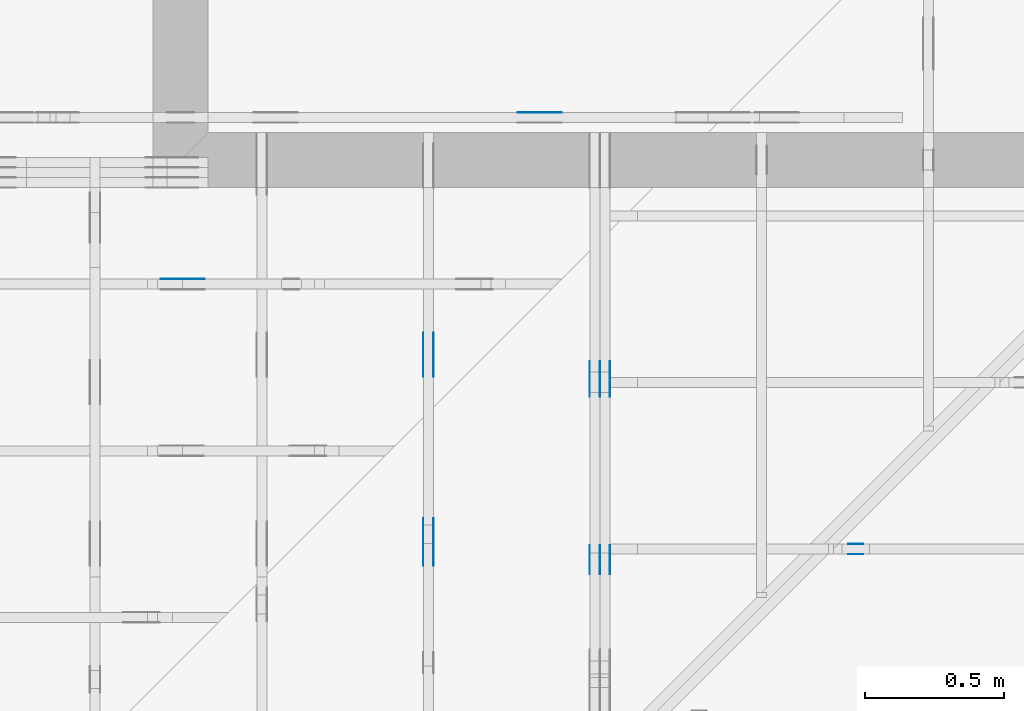
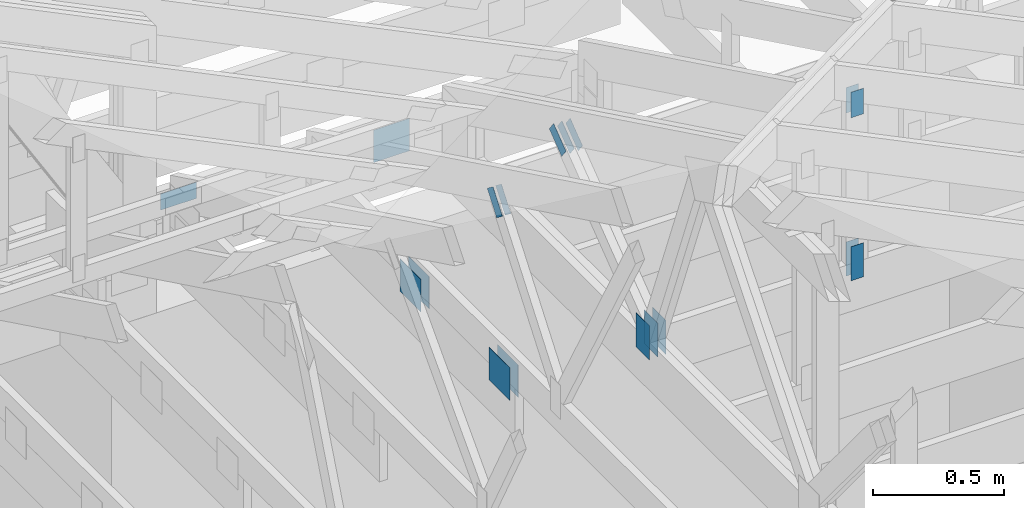
# One storey, part 130 of 159: 20 plates, 5 elements without a shape of their own.
"""IFC2X3 building model written with IfcOpenShell, lengths in millimetres."""

from ifc_helpers import new_model, si_unit, frame, origin, origin_with_axes, origin_2d, place, context, project, spatial, faceted_brep, element, aggregate, save


model = new_model("IFC2X3")

# Units and contexts
model_context = context("Model", 3, precision=1e-05, world=origin())
plan_context = context("Plan", 2, precision=1e-05, world=origin_2d())
ifc_project = project(units=[si_unit("LENGTHUNIT", "METRE", prefix="MILLI"), si_unit("AREAUNIT", "SQUARE_METRE"), si_unit("VOLUMEUNIT", "CUBIC_METRE"), si_unit("SOLIDANGLEUNIT", "STERADIAN"), si_unit("PLANEANGLEUNIT", "RADIAN"), si_unit("MASSUNIT", "GRAM"), si_unit("TIMEUNIT", "SECOND"), si_unit("THERMODYNAMICTEMPERATUREUNIT", "DEGREE_CELSIUS"), si_unit("LUMINOUSINTENSITYUNIT", "LUMEN")], contexts=[model_context, plan_context])

# Site, building, storey
site_placement = place(None, origin_with_axes())
site = spatial("IfcSite", under=ifc_project, at=site_placement, CompositionType="ELEMENT")
building_placement = place(site_placement, origin_with_axes())
building = spatial("IfcBuilding", under=site, at=building_placement, Name="Plan 1", CompositionType="ELEMENT")
storey_placement = place(building_placement, origin_with_axes())
storey = spatial("IfcBuildingStorey", under=building, at=storey_placement, Name="Etasje 1", CompositionType="ELEMENT", Elevation=0.0)

# Assembly, plate
assembly_1_placement = place(storey_placement, frame((10000.012663278096, 9072.000080051337, 1.1021457184401395e-15), z_axis=(9.811600543477555e-09, 1.0, 6.123031769111886e-17), x_axis=(-1.0, 9.811600543477555e-09, 0.0)))
assembly_1 = element("IfcElementAssembly", 1, at=assembly_1_placement, inside=storey, Name="T9 (79)", AssemblyPlace="FACTORY", PredefinedType="TRUSS")
plate_1_placement = place(assembly_1_placement, frame((-7973.47314453125, 147.0, 0.0), z_axis=(0.0, 0.0, 1.0), x_axis=(1.0, 0.0, 0.0)))
plate_1 = element("IfcPlate", 2, at=plate_1_placement, Name="GNT100S 152x159", context=model_context, shape_type="Brep", body=[
    faceted_brep([(159.0, 152.0, 1.0), (0.0, 152.0, 1.0), (0.0, 0.0, 1.0), (159.0, 0.0, 1.0), (0.0, 152.0, 0.0), (159.0, 152.0, 1.9471241025775798e-14), (159.0, 0.0, 1.9471241025775798e-14), (0.0, 0.0, 0.0), (159.00006797736023, -2.9206874025489785e-14, 1.7883461753452272e-30), (159.00006797736023, -2.9145643707798666e-14, 1.0), (6.797736023145262e-05, 6.121783086503054e-17, 1.0), (6.797736023145262e-05, -1.248682608832642e-20, 7.645723283419777e-37), (159.00006797736023, 152.0, 0.0), (159.00006797736023, 152.0, 1.0), (159.00006797736023, 0.0, 1.0), (159.00006797736023, 0.0, 0.0), (6.797736023145262e-05, 152.0, 0.0), (6.797736023145262e-05, 152.0, 1.0), (159.00006797736023, 152.0, 1.0), (159.00006797736023, 152.0, 0.0), (6.797736023145262e-05, 0.0, 0.0), (6.797736023151385e-05, -7.498303609110687e-33, 1.0), (6.797736025012787e-05, 152.0, 1.0), (6.797736025006664e-05, 152.0, -1.1397420192804459e-30)], [[[0, 1, 2, 3]], [[4, 5, 6, 7]], [[8, 9, 10, 11]], [[12, 13, 14, 15]], [[16, 17, 18, 19]], [[20, 21, 22, 23]]]),
])
aggregate(assembly_1, [plate_1])

# Assembly, plates
assembly_2_placement = place(storey_placement, frame((18074.541652722903, -699.9989301294845, 4.408582873760558e-15), z_axis=(-1.0, 1.836909530733566e-16, 6.123031769111886e-17), x_axis=(-1.836909530733566e-16, -1.0, 0.0)))
assembly_2 = element("IfcElementAssembly", 3, at=assembly_2_placement, inside=storey, Name="V5 (30)", AssemblyPlace="FACTORY", PredefinedType="TRUSS")
plate_2_placement = place(assembly_2_placement, frame((-8110.484134151697, 143.49999999999974, 0.0), z_axis=(0.0, 0.0, 1.0), x_axis=(6.123031769111886e-17, 1.0, 0.0)))
plate_2 = element("IfcPlate", 4, at=plate_2_placement, Name="GNT100S 103x159", context=model_context, shape_type="Brep", body=[
    faceted_brep([(159.00000000000023, 103.00024084830329, 1.0), (2.2737367544323206e-13, 103.00024084830329, 1.0), (2.5579538487363607e-13, 0.0002408483032922959, 1.0), (159.00000000000023, 0.0002408483032922959, 1.0), (2.2737367544323206e-13, 103.00024084830329, 2.78443247639729e-29), (159.00000000000023, 103.00024084830329, 1.9471241025775827e-14), (159.00000000000023, 0.0002408483032922959, 1.9471241025775827e-14), (2.5579538487363607e-13, 0.0002408483032922959, 3.1324865359469514e-29), (159.0, -2.92068615386637e-14, 1.788345410772899e-30), (159.0, -2.914563122097258e-14, 1.0), (2.842170943040401e-14, 6.123031769111364e-17, 1.0), (2.842170943040401e-14, -5.220810893244919e-30, 3.1967190959864043e-46), (159.0, 103.0, 0.0), (159.0, 103.0, 1.0), (159.0, 0.0, 1.0), (159.0, 0.0, 0.0), (0.0, 103.0, 0.0), (-3.7491518045553436e-33, 103.0, 1.0), (159.0, 102.99999999999999, 1.0), (159.0, 102.99999999999999, -7.888609052210118e-31), (2.8421709430404004e-14, 0.0, 3.503246160812043e-46), (2.8482939748095126e-14, -7.498303609110687e-33, 1.0), (4.109638519246561e-14, 103.0, 1.0), (4.1035154874774493e-14, 103.0, -2.5125955694867067e-30)], [[[0, 1, 2, 3]], [[4, 5, 6, 7]], [[8, 9, 10, 11]], [[12, 13, 14, 15]], [[16, 17, 18, 19]], [[20, 21, 22, 23]]]),
])
plate_3_placement = place(assembly_2_placement, frame((-8110.484134151697, 143.49999999999974, -37.0), z_axis=(0.0, 0.0, 1.0), x_axis=(6.123031769111886e-17, 1.0, 0.0)))
plate_3 = element("IfcPlate", 5, at=plate_3_placement, Name="GNT100S 103x159", context=model_context, shape_type="Brep", body=[
    faceted_brep([(159.00000000000023, 103.00024084830329, 1.0), (2.2737367544323206e-13, 103.00024084830329, 1.0), (2.5579538487363607e-13, 0.0002408483032922959, 1.0), (159.00000000000023, 0.0002408483032922959, 1.0), (2.2737367544323206e-13, 103.00024084830329, 2.78443247639729e-29), (159.00000000000023, 103.00024084830329, 1.9471241025775827e-14), (159.00000000000023, 0.0002408483032922959, 1.9471241025775827e-14), (2.5579538487363607e-13, 0.0002408483032922959, 3.1324865359469514e-29), (159.0, -2.92068615386637e-14, 1.788345410772899e-30), (159.0, -2.914563122097258e-14, 1.0), (2.842170943040401e-14, 6.123031769111364e-17, 1.0), (2.842170943040401e-14, -5.220810893244919e-30, 3.1967190959864043e-46), (159.0, 103.0, 0.0), (159.0, 103.0, 1.0), (159.0, 0.0, 1.0), (159.0, 0.0, 0.0), (0.0, 103.0, 0.0), (-3.7491518045553436e-33, 103.0, 1.0), (159.0, 102.99999999999999, 1.0), (159.0, 102.99999999999999, -7.888609052210118e-31), (2.8421709430404004e-14, 0.0, 3.503246160812043e-46), (2.8482939748095126e-14, -7.498303609110687e-33, 1.0), (4.109638519246561e-14, 103.0, 1.0), (4.1035154874774493e-14, 103.0, -2.5125955694867067e-30)], [[[0, 1, 2, 3]], [[4, 5, 6, 7]], [[8, 9, 10, 11]], [[12, 13, 14, 15]], [[16, 17, 18, 19]], [[20, 21, 22, 23]]]),
])
plate_4_placement = place(assembly_2_placement, frame((-8110.484134151697, 143.49999999999974, -36.0), z_axis=(0.0, 0.0, 1.0), x_axis=(6.123031769111886e-17, 1.0, 0.0)))
plate_4 = element("IfcPlate", 6, at=plate_4_placement, Name="GNT100S 103x159", context=model_context, shape_type="Brep", body=[
    faceted_brep([(159.00000000000023, 103.00024084830329, 1.0), (2.2737367544323206e-13, 103.00024084830329, 1.0), (2.5579538487363607e-13, 0.0002408483032922959, 1.0), (159.00000000000023, 0.0002408483032922959, 1.0), (2.2737367544323206e-13, 103.00024084830329, 2.78443247639729e-29), (159.00000000000023, 103.00024084830329, 1.9471241025775827e-14), (159.00000000000023, 0.0002408483032922959, 1.9471241025775827e-14), (2.5579538487363607e-13, 0.0002408483032922959, 3.1324865359469514e-29), (159.0, -2.92068615386637e-14, 1.788345410772899e-30), (159.0, -2.914563122097258e-14, 1.0), (2.842170943040401e-14, 6.123031769111364e-17, 1.0), (2.842170943040401e-14, -5.220810893244919e-30, 3.1967190959864043e-46), (159.0, 103.0, 0.0), (159.0, 103.0, 1.0), (159.0, 0.0, 1.0), (159.0, 0.0, 0.0), (0.0, 103.0, 0.0), (-3.7491518045553436e-33, 103.0, 1.0), (159.0, 102.99999999999999, 1.0), (159.0, 102.99999999999999, -7.888609052210118e-31), (2.8421709430404004e-14, 0.0, 3.503246160812043e-46), (2.8482939748095126e-14, -7.498303609110687e-33, 1.0), (4.109638519246561e-14, 103.0, 1.0), (4.1035154874774493e-14, 103.0, -2.5125955694867067e-30)], [[[0, 1, 2, 3]], [[4, 5, 6, 7]], [[8, 9, 10, 11]], [[12, 13, 14, 15]], [[16, 17, 18, 19]], [[20, 21, 22, 23]]]),
])
plate_5_placement = place(assembly_2_placement, frame((-8110.484134151697, 143.49999999999974, -73.0), z_axis=(0.0, 0.0, 1.0), x_axis=(6.123031769111886e-17, 1.0, 0.0)))
plate_5 = element("IfcPlate", 7, at=plate_5_placement, Name="GNT100S 103x159", context=model_context, shape_type="Brep", body=[
    faceted_brep([(159.00000000000023, 103.00024084830329, 1.0), (2.2737367544323206e-13, 103.00024084830329, 1.0), (2.5579538487363607e-13, 0.0002408483032922959, 1.0), (159.00000000000023, 0.0002408483032922959, 1.0), (2.2737367544323206e-13, 103.00024084830329, 2.78443247639729e-29), (159.00000000000023, 103.00024084830329, 1.9471241025775827e-14), (159.00000000000023, 0.0002408483032922959, 1.9471241025775827e-14), (2.5579538487363607e-13, 0.0002408483032922959, 3.1324865359469514e-29), (159.0, -2.92068615386637e-14, 1.788345410772899e-30), (159.0, -2.914563122097258e-14, 1.0), (2.842170943040401e-14, 6.123031769111364e-17, 1.0), (2.842170943040401e-14, -5.220810893244919e-30, 3.1967190959864043e-46), (159.0, 103.0, 0.0), (159.0, 103.0, 1.0), (159.0, 0.0, 1.0), (159.0, 0.0, 0.0), (0.0, 103.0, 0.0), (-3.7491518045553436e-33, 103.0, 1.0), (159.0, 102.99999999999999, 1.0), (159.0, 102.99999999999999, -7.888609052210118e-31), (2.8421709430404004e-14, 0.0, 3.503246160812043e-46), (2.8482939748095126e-14, -7.498303609110687e-33, 1.0), (4.109638519246561e-14, 103.0, 1.0), (4.1035154874774493e-14, 103.0, -2.5125955694867067e-30)], [[[0, 1, 2, 3]], [[4, 5, 6, 7]], [[8, 9, 10, 11]], [[12, 13, 14, 15]], [[16, 17, 18, 19]], [[20, 21, 22, 23]]]),
])
plate_6_placement = place(assembly_2_placement, frame((-8876.552454339913, 758.5722089171368, 0.0), z_axis=(0.0, 0.0, 1.0), x_axis=(0.7964129491034228, -0.6047531847790377, 0.0)))
plate_6 = element("IfcPlate", 8, at=plate_6_placement, Name="GNT100S 55x119", context=model_context, shape_type="Brep", body=[
    faceted_brep([(119.00024115164888, 55.00002240925187, 1.0), (0.0, 55.00002240925187, 1.0), (0.0005573403959715506, 0.0004177808596068644, 1.0), (119.0000207450239, 0.0004177808596068644, 1.0), (0.0, 55.00002240925187, 0.0), (119.00024115164888, 55.00002240925187, 1.4572845142070435e-14), (119.0000207450239, 0.0, 1.4572818150935097e-14), (0.0005573403959715506, 0.0, 6.825225901486405e-20), (119.00029540911692, 0.00021945880050767798, 1.3384505936089834e-30), (119.00029540911692, 0.0002194588005077392, 1.0), (0.0002954091169158346, 0.00021945880052959843, 1.0), (0.0002954091169158346, 0.0002194588005295372, 3.009265538105056e-36), (119.00029540911692, 55.00021945880144, -5.522026336547083e-29), (119.00029540911692, 55.00021945880144, 1.0), (119.00029540911692, 0.00021945880052953726, 1.0), (119.00029540911692, 0.00021945880052953726, 0.0), (0.0002954091169158346, 55.00021945880144, 0.0), (0.0002954091169158346, 55.00021945880144, 1.0), (119.00029540911783, 55.00021945880143, 1.0), (119.00029540911783, 55.00021945880143, -3.944304526105059e-31), (0.0002954091169158346, 0.00021945880052953726, -3.009265538105056e-36), (0.00029540911691589586, 0.00021945880052953726, 1.0), (0.0002954091169226312, 55.00021945880144, 1.0), (0.00029540911692256994, 55.00021945880144, -4.124078049351455e-31)], [[[0, 1, 2, 3]], [[4, 5, 6, 7]], [[8, 9, 10, 11]], [[12, 13, 14, 15]], [[16, 17, 18, 19]], [[20, 21, 22, 23]]]),
])
plate_7_placement = place(assembly_2_placement, frame((-8876.552454339913, 758.5722089171368, -37.0), z_axis=(0.0, 0.0, 1.0), x_axis=(0.7964129491034228, -0.6047531847790377, 0.0)))
plate_7 = element("IfcPlate", 9, at=plate_7_placement, Name="GNT100S 55x119", context=model_context, shape_type="Brep", body=[
    faceted_brep([(119.00024115164888, 55.00002240925187, 1.0), (0.0, 55.00002240925187, 1.0), (0.0005573403959715506, 0.0004177808596068644, 1.0), (119.0000207450239, 0.0004177808596068644, 1.0), (0.0, 55.00002240925187, 0.0), (119.00024115164888, 55.00002240925187, 1.4572845142070435e-14), (119.0000207450239, 0.0, 1.4572818150935097e-14), (0.0005573403959715506, 0.0, 6.825225901486405e-20), (119.00029540911692, 0.00021945880050767798, 1.3384505936089834e-30), (119.00029540911692, 0.0002194588005077392, 1.0), (0.0002954091169158346, 0.00021945880052959843, 1.0), (0.0002954091169158346, 0.0002194588005295372, 3.009265538105056e-36), (119.00029540911692, 55.00021945880144, -5.522026336547083e-29), (119.00029540911692, 55.00021945880144, 1.0), (119.00029540911692, 0.00021945880052953726, 1.0), (119.00029540911692, 0.00021945880052953726, 0.0), (0.0002954091169158346, 55.00021945880144, 0.0), (0.0002954091169158346, 55.00021945880144, 1.0), (119.00029540911783, 55.00021945880143, 1.0), (119.00029540911783, 55.00021945880143, -3.944304526105059e-31), (0.0002954091169158346, 0.00021945880052953726, -3.009265538105056e-36), (0.00029540911691589586, 0.00021945880052953726, 1.0), (0.0002954091169226312, 55.00021945880144, 1.0), (0.00029540911692256994, 55.00021945880144, -4.124078049351455e-31)], [[[0, 1, 2, 3]], [[4, 5, 6, 7]], [[8, 9, 10, 11]], [[12, 13, 14, 15]], [[16, 17, 18, 19]], [[20, 21, 22, 23]]]),
])
plate_8_placement = place(assembly_2_placement, frame((-8876.552454339913, 758.5722089171368, -36.0), z_axis=(0.0, 0.0, 1.0), x_axis=(0.7964129491034228, -0.6047531847790377, 0.0)))
plate_8 = element("IfcPlate", 10, at=plate_8_placement, Name="GNT100S 55x119", context=model_context, shape_type="Brep", body=[
    faceted_brep([(119.00024115164888, 55.00002240925187, 1.0), (0.0, 55.00002240925187, 1.0), (0.0005573403959715506, 0.0004177808596068644, 1.0), (119.0000207450239, 0.0004177808596068644, 1.0), (0.0, 55.00002240925187, 0.0), (119.00024115164888, 55.00002240925187, 1.4572845142070435e-14), (119.0000207450239, 0.0, 1.4572818150935097e-14), (0.0005573403959715506, 0.0, 6.825225901486405e-20), (119.00029540911692, 0.00021945880050767798, 1.3384505936089834e-30), (119.00029540911692, 0.0002194588005077392, 1.0), (0.0002954091169158346, 0.00021945880052959843, 1.0), (0.0002954091169158346, 0.0002194588005295372, 3.009265538105056e-36), (119.00029540911692, 55.00021945880144, -5.522026336547083e-29), (119.00029540911692, 55.00021945880144, 1.0), (119.00029540911692, 0.00021945880052953726, 1.0), (119.00029540911692, 0.00021945880052953726, 0.0), (0.0002954091169158346, 55.00021945880144, 0.0), (0.0002954091169158346, 55.00021945880144, 1.0), (119.00029540911783, 55.00021945880143, 1.0), (119.00029540911783, 55.00021945880143, -3.944304526105059e-31), (0.0002954091169158346, 0.00021945880052953726, -3.009265538105056e-36), (0.00029540911691589586, 0.00021945880052953726, 1.0), (0.0002954091169226312, 55.00021945880144, 1.0), (0.00029540911692256994, 55.00021945880144, -4.124078049351455e-31)], [[[0, 1, 2, 3]], [[4, 5, 6, 7]], [[8, 9, 10, 11]], [[12, 13, 14, 15]], [[16, 17, 18, 19]], [[20, 21, 22, 23]]]),
])
plate_9_placement = place(assembly_2_placement, frame((-8876.552454339913, 758.5722089171368, -73.0), z_axis=(0.0, 0.0, 1.0), x_axis=(0.7964129491034228, -0.6047531847790377, 0.0)))
plate_9 = element("IfcPlate", 11, at=plate_9_placement, Name="GNT100S 55x119", context=model_context, shape_type="Brep", body=[
    faceted_brep([(119.00024115164888, 55.00002240925187, 1.0), (0.0, 55.00002240925187, 1.0), (0.0005573403959715506, 0.0004177808596068644, 1.0), (119.0000207450239, 0.0004177808596068644, 1.0), (0.0, 55.00002240925187, 0.0), (119.00024115164888, 55.00002240925187, 1.4572845142070435e-14), (119.0000207450239, 0.0, 1.4572818150935097e-14), (0.0005573403959715506, 0.0, 6.825225901486405e-20), (119.00029540911692, 0.00021945880050767798, 1.3384505936089834e-30), (119.00029540911692, 0.0002194588005077392, 1.0), (0.0002954091169158346, 0.00021945880052959843, 1.0), (0.0002954091169158346, 0.0002194588005295372, 3.009265538105056e-36), (119.00029540911692, 55.00021945880144, -5.522026336547083e-29), (119.00029540911692, 55.00021945880144, 1.0), (119.00029540911692, 0.00021945880052953726, 1.0), (119.00029540911692, 0.00021945880052953726, 0.0), (0.0002954091169158346, 55.00021945880144, 0.0), (0.0002954091169158346, 55.00021945880144, 1.0), (119.00029540911783, 55.00021945880143, 1.0), (119.00029540911783, 55.00021945880143, -3.944304526105059e-31), (0.0002954091169158346, 0.00021945880052953726, -3.009265538105056e-36), (0.00029540911691589586, 0.00021945880052953726, 1.0), (0.0002954091169226312, 55.00021945880144, 1.0), (0.00029540911692256994, 55.00021945880144, -4.124078049351455e-31)], [[[0, 1, 2, 3]], [[4, 5, 6, 7]], [[8, 9, 10, 11]], [[12, 13, 14, 15]], [[16, 17, 18, 19]], [[20, 21, 22, 23]]]),
])
aggregate(assembly_2, [plate_2, plate_3, plate_4, plate_5, plate_6, plate_7, plate_8, plate_9])

assembly_3_placement = place(storey_placement, frame((17475.02226140475, -699.9989301294827, 1.1021457184401395e-15), z_axis=(-1.0, 1.836909530733566e-16, 6.123031769111886e-17), x_axis=(-1.836909530733566e-16, -1.0, 0.0)))
assembly_3 = element("IfcElementAssembly", 12, at=assembly_3_placement, inside=storey, Name="V6 (31)", AssemblyPlace="FACTORY", PredefinedType="TRUSS")
plate_10_placement = place(assembly_3_placement, frame((-8312.218750000002, 1032.4410400390623, 0.0), z_axis=(0.0, 0.0, 1.0), x_axis=(0.6077192601701954, -0.7941519381190169, 0.0)))
plate_10 = element("IfcPlate", 13, at=plate_10_placement, Name="GNT100S 55x119", context=model_context, shape_type="Brep", body=[
    faceted_brep([(119.00007993496365, 55.00028215261682, 1.0), (0.00021435704820760293, 55.00028215261682, 1.0), (0.0, 0.0, 1.0), (119.00045905375555, 0.0, 1.0), (0.00021435704820760293, 55.00028215261682, 2.6250300322164017e-20), (119.00007993496365, 55.00028215261682, 1.4572825399372727e-14), (119.00045905375555, 0.0005855320823684451, 1.457287182650087e-14), (0.0, 0.0005855320823684451, 0.0), (119.00022031500066, 0.00023279101330987532, 1.3384490889762144e-30), (119.00022031500066, 0.00023279101330993656, 1.0), (0.0002203150006607757, 0.00023279101333179578, 1.0), (0.0002203150006607757, 0.00023279101333173455, 3.009265538105056e-36), (119.00022031500066, 55.00023279101333, 5.522026336547083e-29), (119.00022031500066, 55.00023279101333, 1.0), (119.00022031500066, 0.00023279101333173458, 1.0), (119.00022031500066, 0.00023279101333173458, 0.0), (0.000220314999751281, 55.00023279101333, 0.0), (0.000220314999751281, 55.00023279101333, 1.0), (119.00022031499975, 55.000232791013325, 1.0), (119.00022031499975, 55.000232791013325, -3.944304526105059e-31), (0.00022031500066077575, 0.00023279101333173455, -4.513898307157584e-36), (0.00022031500066083698, 0.00023279101333173455, 1.0), (0.00022031499976385077, 55.00023279101333, 1.0), (0.00022031499976378954, 55.00023279101333, -7.659032184308083e-31)], [[[0, 1, 2, 3]], [[4, 5, 6, 7]], [[8, 9, 10, 11]], [[12, 13, 14, 15]], [[16, 17, 18, 19]], [[20, 21, 22, 23]]]),
])
plate_11_placement = place(assembly_3_placement, frame((-8312.218750000002, 1032.4410400390623, -37.00000000000001), z_axis=(0.0, 0.0, 1.0), x_axis=(0.6077192601701954, -0.7941519381190169, 0.0)))
plate_11 = element("IfcPlate", 14, at=plate_11_placement, Name="GNT100S 55x119", context=model_context, shape_type="Brep", body=[
    faceted_brep([(119.00007993496365, 55.00028215261682, 1.0), (0.00021435704820760293, 55.00028215261682, 1.0), (0.0, 0.0, 1.0), (119.00045905375555, 0.0, 1.0), (0.00021435704820760293, 55.00028215261682, 2.6250300322164017e-20), (119.00007993496365, 55.00028215261682, 1.4572825399372727e-14), (119.00045905375555, 0.0005855320823684451, 1.457287182650087e-14), (0.0, 0.0005855320823684451, 0.0), (119.00022031500066, 0.00023279101330987532, 1.3384490889762144e-30), (119.00022031500066, 0.00023279101330993656, 1.0), (0.0002203150006607757, 0.00023279101333179578, 1.0), (0.0002203150006607757, 0.00023279101333173455, 3.009265538105056e-36), (119.00022031500066, 55.00023279101333, 5.522026336547083e-29), (119.00022031500066, 55.00023279101333, 1.0), (119.00022031500066, 0.00023279101333173458, 1.0), (119.00022031500066, 0.00023279101333173458, 0.0), (0.000220314999751281, 55.00023279101333, 0.0), (0.000220314999751281, 55.00023279101333, 1.0), (119.00022031499975, 55.000232791013325, 1.0), (119.00022031499975, 55.000232791013325, -3.944304526105059e-31), (0.00022031500066077575, 0.00023279101333173455, -4.513898307157584e-36), (0.00022031500066083698, 0.00023279101333173455, 1.0), (0.00022031499976385077, 55.00023279101333, 1.0), (0.00022031499976378954, 55.00023279101333, -7.659032184308083e-31)], [[[0, 1, 2, 3]], [[4, 5, 6, 7]], [[8, 9, 10, 11]], [[12, 13, 14, 15]], [[16, 17, 18, 19]], [[20, 21, 22, 23]]]),
])
plate_12_placement = place(assembly_3_placement, frame((-8140.0, 299.0, 0.0), z_axis=(0.0, 0.0, 1.0), x_axis=(-1.0, 1.2246063538223773e-16, 0.0)))
plate_12 = element("IfcPlate", 15, at=plate_12_placement, Name="GNT100S 152x159", context=model_context, shape_type="Brep", body=[
    faceted_brep([(159.0, 151.99999999999997, 1.0), (0.0, 151.99999999999997, 1.0), (0.0, 0.0, 1.0), (159.0, 0.0, 1.0), (0.0, 151.99999999999997, 0.0), (159.0, 151.99999999999997, 1.9471241025775798e-14), (159.0, 0.0, 1.9471241025775798e-14), (0.0, 0.0, 0.0), (159.0, -2.92068615386637e-14, 1.788345410772899e-30), (159.0, -2.914563122097258e-14, 1.0), (1.1247455413666031e-32, 6.123031769111886e-17, 1.0), (0.0, 0.0, 0.0), (159.0, 152.0, 0.0), (159.0, 152.0, 1.0), (159.0, 0.0, 1.0), (159.0, 0.0, 0.0), (0.0, 151.99999999999997, 0.0), (0.0, 151.99999999999997, 1.0), (159.0, 152.0, 1.0), (159.0, 152.0, 0.0), (0.0, 0.0, 0.0), (6.123031769111886e-17, -7.498303609110687e-33, 1.0), (1.867524689579125e-14, 151.99999999999997, 1.0), (1.861401657810013e-14, 151.99999999999997, -1.1397421485848243e-30)], [[[0, 1, 2, 3]], [[4, 5, 6, 7]], [[8, 9, 10, 11]], [[12, 13, 14, 15]], [[16, 17, 18, 19]], [[20, 21, 22, 23]]]),
])
plate_13_placement = place(assembly_3_placement, frame((-8140.0, 299.0, -37.0), z_axis=(0.0, 0.0, 1.0), x_axis=(-1.0, 1.2246063538223773e-16, 0.0)))
plate_13 = element("IfcPlate", 16, at=plate_13_placement, Name="GNT100S 152x159", context=model_context, shape_type="Brep", body=[
    faceted_brep([(159.0, 151.99999999999997, 1.0), (0.0, 151.99999999999997, 1.0), (0.0, 0.0, 1.0), (159.0, 0.0, 1.0), (0.0, 151.99999999999997, 0.0), (159.0, 151.99999999999997, 1.9471241025775798e-14), (159.0, 0.0, 1.9471241025775798e-14), (0.0, 0.0, 0.0), (159.0, -2.92068615386637e-14, 1.788345410772899e-30), (159.0, -2.914563122097258e-14, 1.0), (1.1247455413666031e-32, 6.123031769111886e-17, 1.0), (0.0, 0.0, 0.0), (159.0, 152.0, 0.0), (159.0, 152.0, 1.0), (159.0, 0.0, 1.0), (159.0, 0.0, 0.0), (0.0, 151.99999999999997, 0.0), (0.0, 151.99999999999997, 1.0), (159.0, 152.0, 1.0), (159.0, 152.0, 0.0), (0.0, 0.0, 0.0), (6.123031769111886e-17, -7.498303609110687e-33, 1.0), (1.867524689579125e-14, 151.99999999999997, 1.0), (1.861401657810013e-14, 151.99999999999997, -1.1397421485848243e-30)], [[[0, 1, 2, 3]], [[4, 5, 6, 7]], [[8, 9, 10, 11]], [[12, 13, 14, 15]], [[16, 17, 18, 19]], [[20, 21, 22, 23]]]),
])
plate_14_placement = place(assembly_3_placement, frame((-8979.49946198694, 147.0, 0.0), z_axis=(0.0, 0.0, 1.0), x_axis=(1.0, 0.0, 0.0)))
plate_14 = element("IfcPlate", 17, at=plate_14_placement, Name="GNT100S 152x159", context=model_context, shape_type="Brep", body=[
    faceted_brep([(159.00043854943942, 152.0, 1.0), (0.00043854943942278624, 152.0, 1.0), (0.00043854943942278624, 0.0, 1.0), (159.00043854943942, 0.0, 1.0), (0.00043854943942278624, 152.0, 5.3705042998238576e-20), (159.00043854943942, 152.0, 1.9471294730818797e-14), (159.00043854943942, 0.0, 1.9471294730818797e-14), (0.00043854943942278624, 0.0, 5.3705042998238576e-20), (159.0, 5.6058266752548325e-14, 1.788345410772899e-30), (159.0, 5.6119497070239444e-14, 1.0), (1.1247455413666031e-32, 8.532635860890314e-14, 1.0), (0.0, 8.526512829121202e-14, 0.0), (159.0, 152.0000000000001, 0.0), (159.0, 152.0000000000001, 1.0), (159.0, 8.526512829121202e-14, 1.0), (159.0, 8.526512829121202e-14, 0.0), (4.861730685829017e-63, 152.0000000000001, 0.0), (-3.7491518045553436e-33, 152.0000000000001, 1.0), (159.0, 152.0000000000001, 1.0), (159.0, 152.0000000000001, 0.0), (1.0441621786489838e-29, 8.526512829121202e-14, -6.393438191972809e-46), (6.12303176911293e-17, 8.526512829121202e-14, 1.0), (1.8675246895791266e-14, 152.0000000000001, 1.0), (1.8614016578100147e-14, 152.0000000000001, -1.1397421485848253e-30)], [[[0, 1, 2, 3]], [[4, 5, 6, 7]], [[8, 9, 10, 11]], [[12, 13, 14, 15]], [[16, 17, 18, 19]], [[20, 21, 22, 23]]]),
])
plate_15_placement = place(assembly_3_placement, frame((-8979.49946198694, 147.0, -37.0), z_axis=(0.0, 0.0, 1.0), x_axis=(1.0, 0.0, 0.0)))
plate_15 = element("IfcPlate", 18, at=plate_15_placement, Name="GNT100S 152x159", context=model_context, shape_type="Brep", body=[
    faceted_brep([(159.00043854943942, 152.0, 1.0), (0.00043854943942278624, 152.0, 1.0), (0.00043854943942278624, 0.0, 1.0), (159.00043854943942, 0.0, 1.0), (0.00043854943942278624, 152.0, 5.3705042998238576e-20), (159.00043854943942, 152.0, 1.9471294730818797e-14), (159.00043854943942, 0.0, 1.9471294730818797e-14), (0.00043854943942278624, 0.0, 5.3705042998238576e-20), (159.0, 5.6058266752548325e-14, 1.788345410772899e-30), (159.0, 5.6119497070239444e-14, 1.0), (1.1247455413666031e-32, 8.532635860890314e-14, 1.0), (0.0, 8.526512829121202e-14, 0.0), (159.0, 152.0000000000001, 0.0), (159.0, 152.0000000000001, 1.0), (159.0, 8.526512829121202e-14, 1.0), (159.0, 8.526512829121202e-14, 0.0), (4.861730685829017e-63, 152.0000000000001, 0.0), (-3.7491518045553436e-33, 152.0000000000001, 1.0), (159.0, 152.0000000000001, 1.0), (159.0, 152.0000000000001, 0.0), (1.0441621786489838e-29, 8.526512829121202e-14, -6.393438191972809e-46), (6.12303176911293e-17, 8.526512829121202e-14, 1.0), (1.8675246895791266e-14, 152.0000000000001, 1.0), (1.8614016578100147e-14, 152.0000000000001, -1.1397421485848253e-30)], [[[0, 1, 2, 3]], [[4, 5, 6, 7]], [[8, 9, 10, 11]], [[12, 13, 14, 15]], [[16, 17, 18, 19]], [[20, 21, 22, 23]]]),
])
aggregate(assembly_3, [plate_10, plate_11, plate_12, plate_13, plate_14, plate_15])

assembly_4_placement = place(storey_placement, frame((21100.012663101486, 7517.993668449257, 1.1021457184401395e-15), z_axis=(1.2246063538223773e-16, 1.0, 6.123031769111886e-17), x_axis=(-1.0, 1.2246063538223773e-16, 0.0)))
assembly_4 = element("IfcElementAssembly", 19, at=assembly_4_placement, inside=storey, Name="S18 (46)", AssemblyPlace="FACTORY", PredefinedType="TRUSS")
plate_16_placement = place(assembly_4_placement, frame((2040.5946044921875, 1023.5120849609375, 0.0), z_axis=(0.0, 0.0, 1.0), x_axis=(6.123031769111886e-17, -1.0, 0.0)))
plate_16 = element("IfcPlate", 20, at=plate_16_placement, Name="GNT100S 55x119", context=model_context, shape_type="Brep", body=[
    faceted_brep([(119.0, 55.0001220703125, 1.0), (0.0, 55.0001220703125, 1.0), (0.0, 0.0, 1.0), (119.0, 0.0, 1.0), (0.0, 55.0001220703125, 0.0), (119.0, 55.0001220703125, 1.457281561048629e-14), (119.0, 0.0, 1.457281561048629e-14), (0.0, 0.0, 0.0), (119.0000183720665, 3.881499376435889e-05, 1.3384475843434453e-30), (119.0000183720665, 3.881499376442012e-05, 1.0), (1.837206650634471e-05, 3.881499378627934e-05, 1.0), (1.837206650634471e-05, 3.881499378621811e-05, 3.76158192263132e-37), (119.0000183720665, 55.000038814993786, 0.0), (119.0000183720665, 55.000038814993786, 1.0), (119.0000183720665, 3.881499378621811e-05, 1.0), (119.0000183720665, 3.881499378621811e-05, 0.0), (1.837206650634471e-05, 55.000038814993786, 0.0), (1.837206650634471e-05, 55.000038814993786, 1.0), (119.0000183720665, 55.00003881499378, 1.0), (119.0000183720665, 55.00003881499378, -3.944304526105059e-31), (1.8372066506344712e-05, 3.881499378621811e-05, -3.76158192263132e-37), (1.8372066506405942e-05, 3.881499378621811e-05, 1.0), (1.8372066513141277e-05, 55.000038814993786, 1.0), (1.8372066513080047e-05, 55.000038814993786, -4.12407052618761e-31)], [[[0, 1, 2, 3]], [[4, 5, 6, 7]], [[8, 9, 10, 11]], [[12, 13, 14, 15]], [[16, 17, 18, 19]], [[20, 21, 22, 23]]]),
])
plate_17_placement = place(assembly_4_placement, frame((2040.5946044921875, 1023.5120849609375, -37.0), z_axis=(0.0, 0.0, 1.0), x_axis=(6.123031769111886e-17, -1.0, 0.0)))
plate_17 = element("IfcPlate", 21, at=plate_17_placement, Name="GNT100S 55x119", context=model_context, shape_type="Brep", body=[
    faceted_brep([(119.0, 55.0001220703125, 1.0), (0.0, 55.0001220703125, 1.0), (0.0, 0.0, 1.0), (119.0, 0.0, 1.0), (0.0, 55.0001220703125, 0.0), (119.0, 55.0001220703125, 1.457281561048629e-14), (119.0, 0.0, 1.457281561048629e-14), (0.0, 0.0, 0.0), (119.0000183720665, 3.881499376435889e-05, 1.3384475843434453e-30), (119.0000183720665, 3.881499376442012e-05, 1.0), (1.837206650634471e-05, 3.881499378627934e-05, 1.0), (1.837206650634471e-05, 3.881499378621811e-05, 3.76158192263132e-37), (119.0000183720665, 55.000038814993786, 0.0), (119.0000183720665, 55.000038814993786, 1.0), (119.0000183720665, 3.881499378621811e-05, 1.0), (119.0000183720665, 3.881499378621811e-05, 0.0), (1.837206650634471e-05, 55.000038814993786, 0.0), (1.837206650634471e-05, 55.000038814993786, 1.0), (119.0000183720665, 55.00003881499378, 1.0), (119.0000183720665, 55.00003881499378, -3.944304526105059e-31), (1.8372066506344712e-05, 3.881499378621811e-05, -3.76158192263132e-37), (1.8372066506405942e-05, 3.881499378621811e-05, 1.0), (1.8372066513141277e-05, 55.000038814993786, 1.0), (1.8372066513080047e-05, 55.000038814993786, -4.12407052618761e-31)], [[[0, 1, 2, 3]], [[4, 5, 6, 7]], [[8, 9, 10, 11]], [[12, 13, 14, 15]], [[16, 17, 18, 19]], [[20, 21, 22, 23]]]),
])
plate_18_placement = place(assembly_4_placement, frame((2095.5947265625, 143.49999999999997, 0.0), z_axis=(0.0, 0.0, 1.0), x_axis=(6.123031769111886e-17, 1.0, 0.0)))
plate_18 = element("IfcPlate", 22, at=plate_18_placement, Name="GNT100S 55x159", context=model_context, shape_type="Brep", body=[
    faceted_brep([(159.0, 55.0001220703125, 1.0), (0.0, 55.0001220703125, 1.0), (2.842170943040401e-14, 0.0, 1.0), (159.0, 0.0, 1.0), (0.0, 55.0001220703125, 0.0), (159.0, 55.0001220703125, 1.9471241025775798e-14), (159.0, 0.0, 1.9471241025775798e-14), (2.842170943040401e-14, 0.0, 3.4805405954966126e-30), (159.0, 8.325534869790019e-05, 1.788345571668688e-30), (159.0, 8.325534869796142e-05, 1.0), (2.842170943040401e-14, 8.325534872716828e-05, 1.0), (2.842170943040401e-14, 8.325534872710705e-05, 0.0), (159.0, 55.00008325534873, 0.0), (159.0, 55.00008325534873, 1.0), (159.0, 8.325534872710705e-05, 1.0), (159.0, 8.325534872710705e-05, 0.0), (0.0, 55.00008325534873, 0.0), (-3.7491518045553436e-33, 55.00008325534873, 1.0), (159.0, 55.00008325534872, 1.0), (159.0, 55.00008325534872, -7.888609052210118e-31), (2.8421725676001787e-14, 8.325534872710705e-05, -9.947231130626802e-37), (2.8482955993692906e-14, 8.325534872710705e-05, 1.0), (1.0793384397962537e-14, 55.00008325534873, 1.0), (1.0732154080271418e-14, 55.00008325534873, -6.571332038450564e-31)], [[[0, 1, 2, 3]], [[4, 5, 6, 7]], [[8, 9, 10, 11]], [[12, 13, 14, 15]], [[16, 17, 18, 19]], [[20, 21, 22, 23]]]),
])
plate_19_placement = place(assembly_4_placement, frame((2095.5947265625, 143.49999999999997, -37.0), z_axis=(0.0, 0.0, 1.0), x_axis=(6.123031769111886e-17, 1.0, 0.0)))
plate_19 = element("IfcPlate", 23, at=plate_19_placement, Name="GNT100S 55x159", context=model_context, shape_type="Brep", body=[
    faceted_brep([(159.0, 55.0001220703125, 1.0), (0.0, 55.0001220703125, 1.0), (2.842170943040401e-14, 0.0, 1.0), (159.0, 0.0, 1.0), (0.0, 55.0001220703125, 0.0), (159.0, 55.0001220703125, 1.9471241025775798e-14), (159.0, 0.0, 1.9471241025775798e-14), (2.842170943040401e-14, 0.0, 3.4805405954966126e-30), (159.0, 8.325534869790019e-05, 1.788345571668688e-30), (159.0, 8.325534869796142e-05, 1.0), (2.842170943040401e-14, 8.325534872716828e-05, 1.0), (2.842170943040401e-14, 8.325534872710705e-05, 0.0), (159.0, 55.00008325534873, 0.0), (159.0, 55.00008325534873, 1.0), (159.0, 8.325534872710705e-05, 1.0), (159.0, 8.325534872710705e-05, 0.0), (0.0, 55.00008325534873, 0.0), (-3.7491518045553436e-33, 55.00008325534873, 1.0), (159.0, 55.00008325534872, 1.0), (159.0, 55.00008325534872, -7.888609052210118e-31), (2.8421725676001787e-14, 8.325534872710705e-05, -9.947231130626802e-37), (2.8482955993692906e-14, 8.325534872710705e-05, 1.0), (1.0793384397962537e-14, 55.00008325534873, 1.0), (1.0732154080271418e-14, 55.00008325534873, -6.571332038450564e-31)], [[[0, 1, 2, 3]], [[4, 5, 6, 7]], [[8, 9, 10, 11]], [[12, 13, 14, 15]], [[16, 17, 18, 19]], [[20, 21, 22, 23]]]),
])
aggregate(assembly_4, [plate_16, plate_17, plate_18, plate_19])

# Assembly, plate
assembly_5_placement = place(storey_placement, frame((11246.01259527543, 8436.00006782605, 727.7147722720857), z_axis=(0.0, -1.0, 6.123031769111886e-17), x_axis=(1.0, 0.0, 0.0)))
assembly_5 = element("IfcElementAssembly", 24, at=assembly_5_placement, inside=storey, Name="Tr1 (1)", AssemblyPlace="FACTORY", PredefinedType="TRUSS")
plate_20_placement = place(assembly_5_placement, frame((5441.500032033771, 87.86637115478516, -37.0), z_axis=(0.0, 0.0, 1.0), x_axis=(-1.0, 1.2246063538223773e-16, 0.0)))
plate_20 = element("IfcPlate", 25, at=plate_20_placement, Name="GNT100S 76x159", context=model_context, shape_type="Brep", body=[
    faceted_brep([(159.00003203377128, 76.00000381469727, 1.0), (3.2033771276474e-05, 76.00000381469727, 1.0), (3.2033771276474e-05, 0.0, 1.0), (159.00003203377128, 0.0, 1.0), (3.2033771276474e-05, 76.00000381469727, 3.922875984206282e-21), (159.00003203377128, 76.00000381469727, 1.9471244948651783e-14), (159.00003203377128, 1.4210854715202004e-14, 1.9471244948651783e-14), (3.2033771276474e-05, 1.4210854715202004e-14, 3.922875984206282e-21), (159.0, 3.7946664114194538e-06, 1.788345430609366e-30), (159.0, 3.794666411480684e-06, 1.0), (1.1247455413666031e-32, 3.7946664406875456e-06, 1.0), (0.0, 3.7946664406263153e-06, 0.0), (159.0, 76.00000379466644, 0.0), (159.0, 76.00000379466644, 1.0), (159.0, 3.7946664406263153e-06, 1.0), (159.0, 3.7946664406263153e-06, 0.0), (-2.4308653429145085e-63, 76.00000379466644, 0.0), (-3.7491518045553436e-33, 76.00000379466644, 1.0), (159.0, 76.00000379466643, 1.0), (159.0, 76.00000379466643, -7.888609052210118e-31), (4.64697263382753e-22, 3.7946664406263153e-06, -2.8453561067119505e-38), (6.123078238838224e-17, 3.7946664406263153e-06, 1.0), (9.368239071438449e-15, 76.00000379466644, 1.0), (9.30700875374733e-15, 76.00000379466644, -5.698711027459733e-31)], [[[0, 1, 2, 3]], [[4, 5, 6, 7]], [[8, 9, 10, 11]], [[12, 13, 14, 15]], [[16, 17, 18, 19]], [[20, 21, 22, 23]]]),
])
aggregate(assembly_5, [plate_20])

save(model, "model.ifc")
